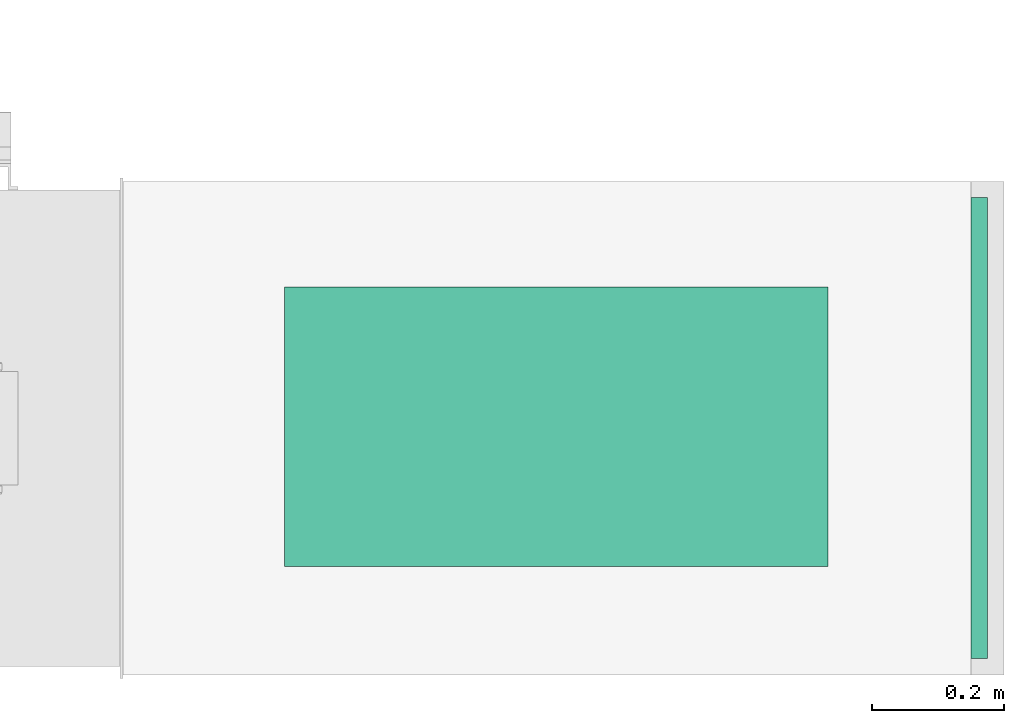
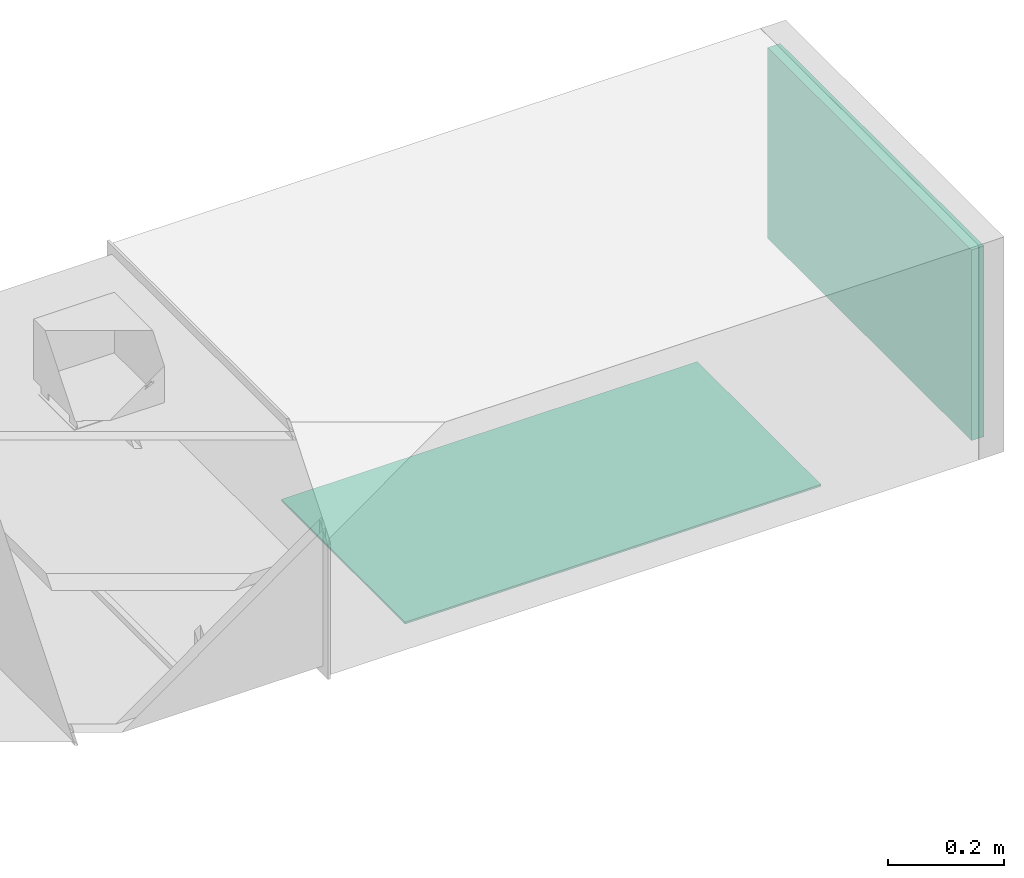
# One storey, part 5 of 8: 1 flow fitting, 1 flow terminal.
"""IFC2X3 building model written with IfcOpenShell, lengths in millimetres."""

from ifc_helpers import new_model, entity, si_unit, converted_unit, derived_unit, direction, frame, origin, origin_2d_with_axis, place, context, subcontext, project, spatial, rectangle, extrude, source, transform, mapped, material, type_object, type_shapes, element, save


model = new_model("IFC2X3")

# Units and contexts
model_context = context("Model", 3, precision=0.01, world=origin(), true_north=direction((6.12303176911189e-17, 1.0)))
body_context = subcontext(model_context, "Body", "Model", "MODEL_VIEW")
ifc_project = project(units=[si_unit("LENGTHUNIT", "METRE", prefix="MILLI"), si_unit("AREAUNIT", "SQUARE_METRE"), si_unit("VOLUMEUNIT", "CUBIC_METRE"), converted_unit("PLANEANGLEUNIT", "DEGREE", entity("IfcRatioMeasure", 0.0174532925199433), si_unit("PLANEANGLEUNIT", "RADIAN"), dimensions=[0, 0, 0, 0, 0, 0, 0]), si_unit("MASSUNIT", "GRAM", prefix="KILO"), derived_unit("MASSDENSITYUNIT", [(si_unit("MASSUNIT", "GRAM", prefix="KILO"), 1), (si_unit("LENGTHUNIT", "METRE"), -3)]), derived_unit("MOMENTOFINERTIAUNIT", [(si_unit("LENGTHUNIT", "METRE"), 4)]), si_unit("TIMEUNIT", "SECOND"), si_unit("FREQUENCYUNIT", "HERTZ"), si_unit("THERMODYNAMICTEMPERATUREUNIT", "DEGREE_CELSIUS"), derived_unit("THERMALTRANSMITTANCEUNIT", [(si_unit("MASSUNIT", "GRAM", prefix="KILO"), 1), (si_unit("THERMODYNAMICTEMPERATUREUNIT", "KELVIN"), -1), (si_unit("TIMEUNIT", "SECOND"), -3)]), derived_unit("VOLUMETRICFLOWRATEUNIT", [(si_unit("LENGTHUNIT", "METRE"), 3), (si_unit("TIMEUNIT", "SECOND"), -1)]), derived_unit("MASSFLOWRATEUNIT", [(si_unit("MASSUNIT", "GRAM", prefix="KILO"), 1), (si_unit("TIMEUNIT", "SECOND"), -1)]), derived_unit("ROTATIONALFREQUENCYUNIT", [(si_unit("TIMEUNIT", "SECOND"), -1)]), si_unit("ELECTRICCURRENTUNIT", "AMPERE"), si_unit("ELECTRICVOLTAGEUNIT", "VOLT"), si_unit("POWERUNIT", "WATT"), si_unit("FORCEUNIT", "NEWTON", prefix="KILO"), si_unit("ILLUMINANCEUNIT", "LUX"), si_unit("LUMINOUSFLUXUNIT", "LUMEN"), si_unit("LUMINOUSINTENSITYUNIT", "CANDELA"), derived_unit("USERDEFINED", [(si_unit("MASSUNIT", "GRAM", prefix="KILO"), -1), (si_unit("LENGTHUNIT", "METRE"), -2), (si_unit("TIMEUNIT", "SECOND"), 3), (si_unit("LUMINOUSFLUXUNIT", "LUMEN"), 1)]), derived_unit("LINEARVELOCITYUNIT", [(si_unit("LENGTHUNIT", "METRE"), 1), (si_unit("TIMEUNIT", "SECOND"), -1)]), si_unit("PRESSUREUNIT", "PASCAL"), derived_unit("USERDEFINED", [(si_unit("LENGTHUNIT", "METRE"), -2), (si_unit("MASSUNIT", "GRAM", prefix="KILO"), 1), (si_unit("TIMEUNIT", "SECOND"), -2)]), derived_unit("LINEARFORCEUNIT", [(si_unit("MASSUNIT", "GRAM", prefix="KILO"), 1), (si_unit("LENGTHUNIT", "METRE"), 1), (si_unit("TIMEUNIT", "SECOND"), -2), (si_unit("LENGTHUNIT", "METRE"), -1)]), derived_unit("PLANARFORCEUNIT", [(si_unit("MASSUNIT", "GRAM", prefix="KILO"), 1), (si_unit("LENGTHUNIT", "METRE"), 1), (si_unit("TIMEUNIT", "SECOND"), -2), (si_unit("LENGTHUNIT", "METRE"), -2)])], contexts=[model_context])

# Site, building, storey
site_placement = place(None, origin())
site = spatial("IfcSite", under=ifc_project, at=site_placement, CompositionType="ELEMENT")
building_placement = place(site_placement, origin())
building = spatial("IfcBuilding", under=site, at=building_placement, CompositionType="ELEMENT")
storey_placement = place(building_placement, frame((0.0, 0.0, 4200.0)))
storey = spatial("IfcBuildingStorey", under=building, at=storey_placement, CompositionType="ELEMENT", Elevation=4200.0)

# Flow fitting
ifc_material_1 = material()
duct_fitting_type = type_object("IfcDuctFittingType", PredefinedType="NOTDEFINED", material=ifc_material_1)
shared_shape_1 = source(origin(), body_context, "Body", "SweptSolid", [
    extrude(rectangle(XDim=24.9999999999999, YDim=700.0, at=origin_2d_with_axis()), frame((12.5, 0.0, -200.0)), (0.0, 0.0, 1.0), 400.0),
])
type_shapes(duct_fitting_type, [shared_shape_1])
flow_fitting_placement = place(storey_placement, frame((65398.0, 9835.42, 2700.0)))
element("IfcFlowFitting", 1, at=flow_fitting_placement, inside=storey, type_object=duct_fitting_type, material=ifc_material_1, context=body_context, shape_type="MappedRepresentation", body=[
    mapped(shared_shape_1, transform((0.0, 0.0, 0.0), scale=1.0)),
])

# Flow terminal
ifc_material_2 = material()
air_terminal_type = type_object("IfcAirTerminalType", PredefinedType="NOTDEFINED", material=ifc_material_2)
shared_shape_2 = source(origin(), body_context, "Body", "SweptSolid", [
    extrude(rectangle(XDim=4.0, YDim=824.999999999999, at=origin_2d_with_axis()), frame((0.0, -2.0, -212.5), z_axis=(0.0, 0.0, 1.0), x_axis=(0.0, 1.0, 0.0)), (0.0, 0.0, 1.0), 425.000000000005),
])
type_shapes(air_terminal_type, [shared_shape_2])
flow_terminal_placement = place(storey_placement, frame((64767.86, 9837.56, 2400.0), z_axis=(0.0, -1.0, 0.0), x_axis=(1.0, 0.0, 0.0)))
element("IfcFlowTerminal", 2, at=flow_terminal_placement, inside=storey, type_object=air_terminal_type, material=ifc_material_2, context=body_context, shape_type="MappedRepresentation", body=[
    mapped(shared_shape_2, transform((0.0, 0.0, 0.0), scale=1.0)),
])

save(model, "model.ifc")
